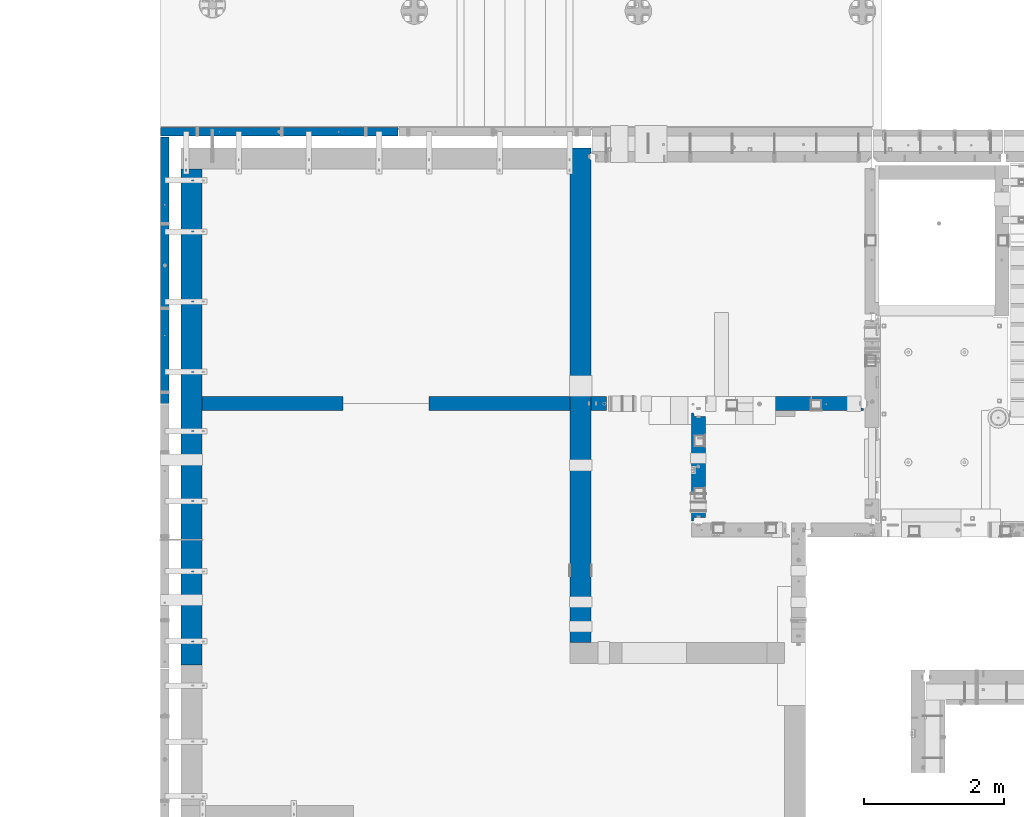
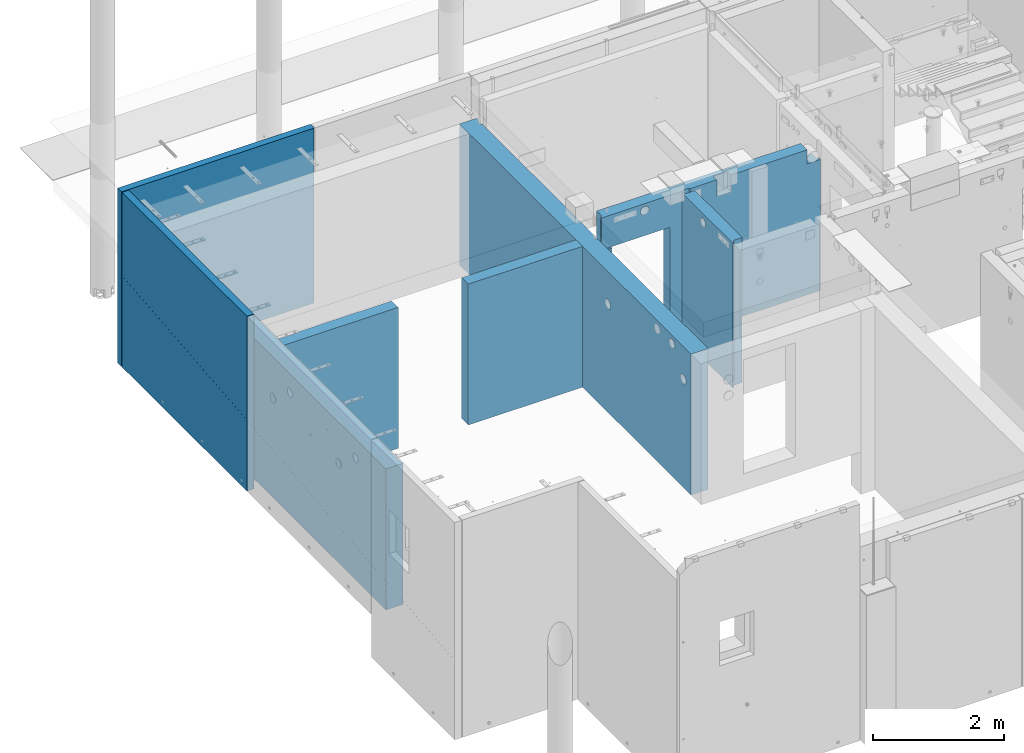
# One storey, part 174 of 264: 9 walls, 8 elements without a shape of their own.
"""IFC2X3 building model written with IfcOpenShell, lengths in millimetres."""

from ifc_helpers import new_model, si_unit, frame, origin_with_axes, place, context, subcontext, project, spatial, faceted_brep, material, type_object, element, aggregate, save


model = new_model("IFC2X3")

# Units and contexts
model_context = context("Model", 3, precision=1e-05, world=origin_with_axes())
body_context = subcontext(model_context, "Body", "Model", "MODEL_VIEW")
ifc_project = project(units=[si_unit("LENGTHUNIT", "METRE", prefix="MILLI"), si_unit("AREAUNIT", "SQUARE_METRE"), si_unit("VOLUMEUNIT", "CUBIC_METRE"), si_unit("MASSUNIT", "GRAM", prefix="KILO"), si_unit("TIMEUNIT", "SECOND"), si_unit("PLANEANGLEUNIT", "RADIAN"), si_unit("SOLIDANGLEUNIT", "STERADIAN"), si_unit("THERMODYNAMICTEMPERATUREUNIT", "DEGREE_CELSIUS"), si_unit("LUMINOUSINTENSITYUNIT", "LUMEN")], contexts=[model_context])

# Site, building, storey
site_placement = place(None, origin_with_axes())
site = spatial("IfcSite", under=ifc_project, at=site_placement, CompositionType="ELEMENT")
building_placement = place(site_placement, origin_with_axes())
building = spatial("IfcBuilding", under=site, at=building_placement, CompositionType="ELEMENT")
storey_placement = place(building_placement, origin_with_axes())
storey = spatial("IfcBuildingStorey", under=building, at=storey_placement, Name="K", CompositionType="ELEMENT", Elevation=0.0)

# Assembly, wall
assembly_1_placement = place(storey_placement, origin_with_axes())
assembly_1 = element("IfcElementAssembly", 1, at=assembly_1_placement, inside=storey, AssemblyPlace="NOTDEFINED", PredefinedType="REINFORCEMENT_UNIT")
ifc_material_1 = material(Name="CONCRETE/Concrete_Undefined")
wall_type_1 = type_object("IfcWallType", PredefinedType="NOTDEFINED")
wall_1_placement = place(assembly_1_placement, frame((13700.0033712105, 16979.999999569, 79645.0), z_axis=(0.0, 0.0, 1.0), x_axis=(1.0, 0.0, 0.0)))
wall_1 = element("IfcWall", 2, at=wall_1_placement, type_object=wall_type_1, material=ifc_material_1, context=body_context, shape_type="Brep", body=[
    faceted_brep([(0.0, 100.0, -1205.0), (0.0, 100.0, 1205.0), (219.998136879898, 100.0, 1205.0), (219.998136879898, 100.0, -1205.0), (0.0, -100.0, 1205.0), (219.998136879898, -100.0, 1205.0), (0.0, -100.0, -1205.0), (219.998136879898, -100.0, -1205.0)], [[[0, 1, 2, 3]], [[1, 4, 5, 2]], [[4, 6, 7, 5]], [[6, 0, 3, 7]], [[5, 7, 3, 2]], [[6, 4, 1, 0]]]),
])

assembly_2_placement = place(storey_placement, origin_with_axes())
assembly_2 = element("IfcElementAssembly", 3, at=assembly_2_placement, inside=storey, AssemblyPlace="NOTDEFINED", PredefinedType="REINFORCEMENT_UNIT")
wall_type_2 = type_object("IfcWallType", PredefinedType="NOTDEFINED")
wall_2_placement = place(assembly_2_placement, frame((11390.0003210833, 16980.0034224637, 79750.0), z_axis=(0.0, 0.0, 1.0), x_axis=(1.0, 0.0, 0.0)))
wall_2 = element("IfcWall", 4, at=wall_2_placement, type_object=wall_type_2, material=ifc_material_1, context=body_context, shape_type="Brep", body=[
    faceted_brep([(0.0, 100.0, -1310.0), (0.0, 100.0, 1310.0), (2010.0, 100.0, 1310.0), (2010.0, 100.0, -1310.0), (0.0, -100.0, 1310.0), (2010.0, -100.0, 1310.0), (0.0, -100.0, -1310.0), (2010.0, -100.0, -1310.0)], [[[0, 1, 2, 3]], [[1, 4, 5, 2]], [[4, 6, 7, 5]], [[6, 0, 3, 7]], [[5, 7, 3, 2]], [[6, 4, 1, 0]]]),
])
aggregate(assembly_2, [wall_2])

assembly_3_placement = place(storey_placement, origin_with_axes())
assembly_3 = element("IfcElementAssembly", 5, at=assembly_3_placement, inside=storey, AssemblyPlace="NOTDEFINED", PredefinedType="REINFORCEMENT_UNIT")
wall_3_placement = place(assembly_3_placement, frame((8150.00032108328, 16980.0034224637, 79750.0), z_axis=(0.0, 0.0, 1.0), x_axis=(1.0, 0.0, 0.0)))
wall_3 = element("IfcWall", 6, at=wall_3_placement, type_object=wall_type_2, material=ifc_material_1, context=body_context, shape_type="Brep", body=[
    faceted_brep([(0.0, 100.0, -1310.0), (0.0, 100.0, 1310.0), (2010.0, 100.0, 1310.0), (2010.0, 100.0, -1310.0), (0.0, -100.0, 1310.0), (2010.0, -100.0, 1310.0), (0.0, -100.0, -1310.0), (2010.0, -100.0, -1310.0)], [[[0, 1, 2, 3]], [[1, 4, 5, 2]], [[4, 6, 7, 5]], [[6, 0, 3, 7]], [[5, 7, 3, 2]], [[6, 4, 1, 0]]]),
])
aggregate(assembly_3, [wall_3])

assembly_4_placement = place(storey_placement, origin_with_axes())
assembly_4 = element("IfcElementAssembly", 7, at=assembly_4_placement, inside=storey, AssemblyPlace="NOTDEFINED", PredefinedType="REINFORCEMENT_UNIT")
ifc_material_2 = material(Name="CONCRETE/C25/30")
wall_type_3 = type_object("IfcWallType", PredefinedType="NOTDEFINED")
wall_4_placement = place(assembly_4_placement, frame((15230.0, 15280.0001284873, 80122.5), z_axis=(0.0, 0.0, 1.0), x_axis=(0.0, 1.0, 0.0)))
wall_4 = element("IfcWall", 8, at=wall_4_placement, type_object=wall_type_3, material=ifc_material_2, context=body_context, shape_type="Brep", body=[
    faceted_brep([(992.588884020672, -100.0, 1168.08857161731), (992.588884020672, 100.0, 1168.08857161731), (985.096352332825, 100.0, 1150.0), (985.096352332825, -100.0, 1150.0), (973.177455637982, 100.0, 1134.46699141101), (973.177455637982, -100.0, 1134.46699141101), (957.644447048991, 100.0, 1122.54809471617), (957.644447048991, -100.0, 1122.54809471617), (939.555875431681, 100.0, 1115.05556302832), (939.555875431681, -100.0, 1115.05556302832), (920.144447048991, 100.0, 1112.5), (920.144447048991, -100.0, 1112.5), (900.733018666302, 100.0, 1115.05556302832), (900.733018666302, -100.0, 1115.05556302832), (882.644447048991, 100.0, 1122.54809471617), (882.644447048991, -100.0, 1122.54809471617), (867.111438460001, 100.0, 1134.46699141101), (867.111438460001, -100.0, 1134.46699141101), (855.192541765158, 100.0, 1150.0), (855.192541765158, -100.0, 1150.0), (847.700010077311, 100.0, 1168.08857161731), (847.700010077311, -100.0, 1168.08857161731), (845.144447048991, 100.0, 1187.5), (845.144447048991, -100.0, 1187.5), (847.700010077311, 100.0, 1206.91142838269), (847.700010077311, -100.0, 1206.91142838269), (855.192541765158, 100.0, 1225.0), (855.192541765158, -100.0, 1225.0), (867.111438460001, 100.0, 1240.53300858899), (867.111438460001, -100.0, 1240.53300858899), (882.644447048991, 100.0, 1252.45190528383), (882.644447048991, -100.0, 1252.45190528383), (900.733018666302, 100.0, 1259.94443697168), (900.733018666302, -100.0, 1259.94443697168), (920.144447048991, 100.0, 1262.5), (920.144447048991, -100.0, 1262.5), (939.555875431681, 100.0, 1259.94443697168), (939.555875431681, -100.0, 1259.94443697168), (957.644447048991, 100.0, 1252.45190528383), (957.644447048991, -100.0, 1252.45190528383), (973.177455637982, 100.0, 1240.53300858899), (973.177455637982, -100.0, 1240.53300858899), (985.096352332825, 100.0, 1225.0), (985.096352332825, -100.0, 1225.0), (992.588884020672, 100.0, 1206.91142838269), (992.588884020672, -100.0, 1206.91142838269), (995.144447048991, 100.0, 1187.5), (995.144447048991, -100.0, 1187.5), (1519.99987151275, -100.0, -1347.5), (1519.99987151275, -100.0, 1347.5), (79.9998715127422, -100.0, 1347.5), (79.9998715127422, -100.0, -1347.5), (1519.99987151275, 57.0, -1347.5), (1519.99987151275, 57.0, 1347.5), (1569.99987151275, 69.9999999999982, 1347.5), (1569.99987151275, 100.0, 1347.5), (29.9998715127422, 100.0, 1347.5), (29.9998715127422, 70.0, 1347.5), (79.9998715127422, 57.0, 1347.5), (29.9998715127422, 100.0, -1347.5), (29.9998715127422, 70.0, -1347.5), (79.9998715127422, 57.0, -1347.5), (1569.99987151275, 100.0, -1347.5), (1569.99987151275, 69.9999999999982, -1347.5)], [[[0, 1, 2, 3]], [[3, 2, 4, 5]], [[5, 4, 6, 7]], [[7, 6, 8, 9]], [[9, 8, 10, 11]], [[11, 10, 12, 13]], [[13, 12, 14, 15]], [[15, 14, 16, 17]], [[17, 16, 18, 19]], [[19, 18, 20, 21]], [[21, 20, 22, 23]], [[23, 22, 24, 25]], [[25, 24, 26, 27]], [[27, 26, 28, 29]], [[29, 28, 30, 31]], [[31, 30, 32, 33]], [[33, 32, 34, 35]], [[35, 34, 36, 37]], [[37, 36, 38, 39]], [[39, 38, 40, 41]], [[41, 40, 42, 43]], [[43, 42, 44, 45]], [[45, 44, 46, 47]], [[47, 46, 1, 0]], [[48, 49, 50, 51], [3, 5, 7, 9, 11, 13, 15, 17, 19, 21, 23, 25, 27, 29, 31, 33, 35, 37, 39, 41, 43, 45, 47, 0]], [[49, 48, 52, 53]], [[49, 53, 54, 55, 56, 57, 58, 50]], [[56, 59, 60, 57]], [[57, 60, 61, 58]], [[50, 58, 61, 51]], [[60, 59, 62, 63, 52, 48, 51, 61]], [[53, 52, 63, 54]], [[62, 55, 54, 63]], [[59, 56, 55, 62], [42, 40, 38, 36, 34, 32, 30, 28, 26, 24, 22, 20, 18, 16, 14, 12, 10, 8, 6, 4, 2, 1, 46, 44]]]),
])
aggregate(assembly_4, [wall_4])

assembly_5_placement = place(storey_placement, origin_with_axes())
assembly_5 = element("IfcElementAssembly", 9, at=assembly_5_placement, inside=storey, AssemblyPlace="NOTDEFINED", PredefinedType="REINFORCEMENT_UNIT")
ifc_material_3 = material(Name="CONCRETE/C30/37")
wall_5_placement = place(assembly_5_placement, frame((13729.9991042544, 16980.0, 80122.5), z_axis=(0.0, 0.0, 1.0), x_axis=(1.0, 0.0, 0.0)))
wall_5 = element("IfcWall", 10, at=wall_5_placement, type_object=wall_type_3, material=ifc_material_3, context=body_context, shape_type="Brep", body=[
    faceted_brep([(3620.00051278574, 100.000000075132, 1347.5), (3620.00051278574, -100.0, 1347.5), (3620.00051278574, -100.0, 1087.5), (3620.00051278574, 100.000000371449, 1087.5), (3854.99999398691, -72.1666613361449, 1087.5), (3820.00089558421, -57.0000048420043, 1087.5), (3820.00089558421, 100.00000001011, 1087.5), (3855.0, -100.0, 1087.5), (2280.00093240244, -100.0, 1037.5), (2280.00093240244, 9.99999999999636, 1037.5), (2030.00093240244, 9.99999999999636, 1037.5), (2030.00093240244, -100.0, 1037.5), (2280.00093240244, 9.99999999999636, 1347.5), (2280.00093240244, -100.0, 1347.5), (2030.00093240244, 9.99999999999636, 1347.5), (2030.00093240244, -100.0, 1347.5), (1565.00089574558, -100.0, 1347.5), (1552.00089574558, -80.0, 1347.5), (1552.00089574558, -80.0, -1347.5), (1565.00089574558, -100.0, -1347.5), (1448.00089574558, -80.0, 1347.5), (1448.00089574558, -80.0, -1347.5), (1435.00089574558, -100.0, 1347.5), (1435.00089574558, -100.0, -1347.5), (3855.0, -100.0, -1347.5), (1209.99657178411, -100.0, -1347.5), (1209.99657178411, 100.0, -1347.5), (3820.00089558421, 100.0, -1347.5), (3820.00089558421, -57.0000048420043, -1347.5), (3855.0, -72.1666613361449, -1347.5), (30.0, 100.0, 1347.5), (30.0000423138954, -56.9999995350736, 1347.5), (0.0, -70.0, 1347.5), (0.0, -100.0, 1347.5), (0.0, -100.0, 752.5), (0.0, -70.0, 752.5), (30.0000423138954, -56.9999995350736, 752.5), (30.0000386454594, 100.0, 752.5), (1209.99657178411, 100.0, 752.5), (1209.99657178411, -100.0, 752.5), (825.234667520259, -100.0, 1185.0), (813.315770825417, -100.0, 1169.46699141101), (797.782762236426, -100.0, 1157.54809471617), (779.694190619115, -100.0, 1150.05556302832), (760.282762236426, -100.0, 1147.5), (740.871333853736, -100.0, 1150.05556302832), (722.782762236426, -100.0, 1157.54809471617), (707.249753647435, -100.0, 1169.46699141101), (695.330856952593, -100.0, 1185.0), (687.838325264745, -100.0, 1203.08857161731), (685.282762236426, -100.0, 1222.5), (687.838325264745, -100.0, 1241.91142838269), (695.330856952593, -100.0, 1260.0), (707.249753647435, -100.0, 1275.53300858899), (722.782762236426, -100.0, 1287.45190528383), (740.871333853736, -100.0, 1294.94443697168), (760.282762236426, -100.0, 1297.5), (779.694190619115, -100.0, 1294.94443697168), (797.782762236426, -100.0, 1287.45190528383), (813.315770825417, -100.0, 1275.53300858899), (825.234667520259, -100.0, 1260.0), (832.727199208106, -100.0, 1241.91142838269), (835.282762236426, -100.0, 1222.5), (832.727199208106, -100.0, 1203.08857161731), (832.727199208106, 100.0, 1203.08857161731), (835.282762236426, 100.0, 1222.5), (825.234667520259, 100.0, 1185.0), (813.315770825417, 100.0, 1169.46699141101), (797.782762236426, 100.0, 1157.54809471617), (779.694190619115, 100.0, 1150.05556302832), (760.282762236426, 100.0, 1147.5), (740.871333853736, 100.0, 1150.05556302832), (722.782762236426, 100.0, 1157.54809471617), (707.249753647435, 100.0, 1169.46699141101), (695.330856952593, 100.0, 1185.0), (687.838325264745, 100.0, 1203.08857161731), (685.282762236426, 100.0, 1222.5), (687.838325264745, 100.0, 1241.91142838269), (695.330856952593, 100.0, 1260.0), (707.249753647435, 100.0, 1275.53300858899), (722.782762236426, 100.0, 1287.45190528383), (740.871333853736, 100.0, 1294.94443697168), (760.282762236426, 100.0, 1297.5), (779.694190619115, 100.0, 1294.94443697168), (797.782762236426, 100.0, 1287.45190528383), (813.315770825417, 100.0, 1275.53300858899), (825.234667520259, 100.0, 1260.0), (832.727199208106, 100.0, 1241.91142838269)], [[[0, 1, 2, 3]], [[4, 5, 6, 3, 2, 7]], [[8, 9, 10, 11]], [[12, 9, 8, 13]], [[14, 10, 9, 12]], [[15, 11, 10, 14]], [[16, 17, 18, 19]], [[20, 21, 18, 17]], [[22, 23, 21, 20]], [[24, 19, 18, 21, 23, 25, 26, 27, 28, 29]], [[24, 29, 4, 7]], [[1, 13, 8, 11, 15, 16, 19, 24, 7, 2]], [[30, 31, 32, 33, 22, 20, 17, 16, 15, 14, 12, 13, 1, 0]], [[34, 33, 32, 35]], [[31, 36, 35, 32]], [[30, 37, 36, 31]], [[38, 39, 34, 35, 36, 37]], [[26, 25, 39, 38]], [[23, 22, 33, 34, 39, 25], [40, 41, 42, 43, 44, 45, 46, 47, 48, 49, 50, 51, 52, 53, 54, 55, 56, 57, 58, 59, 60, 61, 62, 63]], [[64, 63, 62, 65]], [[66, 40, 63, 64]], [[67, 41, 40, 66]], [[68, 42, 41, 67]], [[69, 43, 42, 68]], [[70, 44, 43, 69]], [[71, 45, 44, 70]], [[72, 46, 45, 71]], [[73, 47, 46, 72]], [[74, 48, 47, 73]], [[75, 49, 48, 74]], [[76, 50, 49, 75]], [[77, 51, 50, 76]], [[78, 52, 51, 77]], [[79, 53, 52, 78]], [[80, 54, 53, 79]], [[81, 55, 54, 80]], [[82, 56, 55, 81]], [[83, 57, 56, 82]], [[84, 58, 57, 83]], [[85, 59, 58, 84]], [[86, 60, 59, 85]], [[87, 61, 60, 86]], [[65, 62, 61, 87]], [[27, 26, 38, 37, 30, 0, 3, 6], [86, 85, 84, 83, 82, 81, 80, 79, 78, 77, 76, 75, 74, 73, 72, 71, 70, 69, 68, 67, 66, 64, 65, 87]], [[28, 27, 6, 5]], [[29, 28, 5, 4]]]),
])
aggregate(assembly_5, [wall_5])

assembly_6_placement = place(storey_placement, origin_with_axes())
assembly_6 = element("IfcElementAssembly", 11, at=assembly_6_placement, inside=storey, AssemblyPlace="NOTDEFINED", PredefinedType="REINFORCEMENT_UNIT")
ifc_material_4 = material(Name="CONCRETE/C40/50")
wall_type_4 = type_object("IfcWallType", PredefinedType="NOTDEFINED")
wall_6_placement = place(assembly_6_placement, frame((7620.0, 16985.0, 80115.0), z_axis=(0.0, 0.0, 1.0), x_axis=(0.0, 1.0, 0.0)))
wall_6 = element("IfcWall", 12, at=wall_6_placement, type_object=wall_type_4, material=ifc_material_4, context=body_context, shape_type="Brep", body=[
    faceted_brep([(3800.0, 60.0, 71.9251981614216), (0.0, 60.0, -308.074801838578), (0.0, 59.0002685189247, -308.074801838578), (3800.0, 59.0002685189247, 71.9251981614216), (3800.0, 59.0002685189247, 87.000011593118), (0.0, 59.0002685189247, -292.999988406882), (0.0, 60.0, -292.999988406897), (3800.0, 60.0, 87.0000115931034), (3.63797880709171e-12, -59.9999999999927, -1625.0), (1.81898940354586e-12, 60.0000000000036, -1625.0), (3800.0, 60.0, -1625.0), (3800.0, -60.0, -1625.0), (3.63797880709171e-12, -59.9999999999927, 1625.0), (3800.0, -60.0, 1625.0), (1.81898940354586e-12, 60.0000000000036, 1625.0), (3800.0, 60.0, 1625.0)], [[[0, 1, 2, 3]], [[4, 5, 6, 7]], [[3, 2, 5, 4]], [[8, 9, 10, 11]], [[12, 8, 11, 13]], [[14, 12, 13, 15]], [[14, 15, 7, 6]], [[1, 9, 8, 12, 14, 6, 5, 2]], [[10, 9, 1, 0]], [[15, 13, 11, 10, 0, 3, 4, 7]]]),
])
aggregate(assembly_6, [wall_6])

assembly_7_placement = place(storey_placement, origin_with_axes())
assembly_7 = element("IfcElementAssembly", 13, at=assembly_7_placement, inside=storey, AssemblyPlace="NOTDEFINED", PredefinedType="REINFORCEMENT_UNIT")
wall_7_placement = place(assembly_7_placement, frame((7560.0, 20860.0, 80115.0), z_axis=(0.0, 0.0, 1.0), x_axis=(1.0, 0.0, 0.0)))
wall_7 = element("IfcWall", 14, at=wall_7_placement, type_object=wall_type_4, material=ifc_material_4, context=body_context, shape_type="Brep", body=[
    faceted_brep([(3385.0, 40.0, 385.0), (1515.0, 40.0, 385.0), (1515.0, 40.0, 485.0), (3385.0, 40.0, 485.0), (3385.0, 60.0, 385.0), (1515.0, 60.0, 385.0), (1515.0, 60.0, 485.0), (3385.0, 60.0, 485.0), (3.63797880709171e-12, -59.9999999999927, -1625.0), (3.63797880709171e-12, -59.9999999999927, 1625.0), (1.81898940354586e-12, 60.0000000000036, 1625.0), (1.81898940354586e-12, 60.0000000000036, -1625.0), (3385.0, 60.0, -1625.0), (3385.0, -60.0, -1625.0), (3385.0, -60.0, 1625.0), (3385.0, 60.0, 1625.0)], [[[0, 1, 2, 3]], [[4, 5, 1, 0]], [[6, 2, 1, 5]], [[7, 3, 2, 6]], [[8, 9, 10, 11]], [[8, 11, 12, 13]], [[9, 8, 13, 14]], [[10, 9, 14, 15]], [[5, 4, 12, 11, 10, 15, 7, 6]], [[15, 14, 13, 12, 4, 0, 3, 7]]]),
])
aggregate(assembly_7, [wall_7])

# Wall
wall_type_5 = type_object("IfcWallType", PredefinedType="NOTDEFINED")
wall_8_placement = place(assembly_1_placement, frame((13550.0033728411, 13575.0031172879, 79750.0), z_axis=(0.0, 0.0, 1.0), x_axis=(0.0, 1.0, 0.0)))
wall_8 = element("IfcWall", 15, at=wall_8_placement, type_object=wall_type_5, material=ifc_material_1, context=body_context, shape_type="Brep", body=[
    faceted_brep([(3367.99688226059, -129.99999734863, 1310.0), (3367.99688226059, -129.99999734863, 1100.0), (3441.99688230155, -129.99999939036, 1100.0), (3441.99688230155, -129.99999939036, 1310.0), (3354.99688298958, -150.0, 1310.0), (3354.99688298958, -149.999998131263, 1100.0), (3454.99688271211, -150.0, 1100.0), (3454.99688271211, -150.0, 1310.0), (6892.99688271211, -130.0, -1300.0), (6892.99688226059, -129.999997348625, -1310.0), (6966.99688230153, -129.999999390373, -1310.0), (6966.99688271211, -130.0, -1300.0), (6879.99688271211, -150.0, -1300.0), (6879.99688298958, -150.0, -1310.0), (0.0, -150.0, -1310.0), (0.0, -150.0, 1310.0), (0.0, 150.0, 1310.0), (0.0, 150.0, -1310.0), (297.868543651701, -149.999999999996, 750.0), (297.868543651701, 150.0, 750.0), (305.860577452071, 150.0, 730.705523608209), (305.860577452071, -149.999999999996, 730.705523608209), (285.15505384387, -149.999999999996, 766.568542494919), (285.15505384387, 150.0, 766.568542494919), (268.586511348945, -149.999999999996, 779.282032302755), (268.586511348945, 150.0, 779.282032302755), (249.292034957147, -149.999999999996, 787.274066103128), (249.292034957147, 150.0, 787.274066103128), (228.586511348945, -149.999999999996, 790.0), (228.586511348945, 150.0, 790.0), (207.880987740744, -149.999999999996, 787.274066103128), (207.880987740744, 150.0, 787.274066103128), (188.586511348945, -149.999999999996, 779.282032302755), (188.586511348945, 150.0, 779.282032302755), (172.017968854021, -149.999999999996, 766.568542494919), (172.017968854021, 150.0, 766.568542494919), (159.30447904619, -149.999999999996, 750.0), (159.30447904619, 150.0, 750.0), (151.31244524582, -149.999999999996, 730.705523608209), (151.31244524582, 150.0, 730.705523608209), (148.586511348945, -149.999999999996, 710.0), (148.586511348945, 150.0, 710.0), (151.31244524582, -149.999999999996, 689.294476391791), (151.31244524582, 150.0, 689.294476391791), (159.30447904619, -149.999999999996, 670.0), (159.30447904619, 150.0, 670.0), (172.017968854021, -149.999999999996, 653.431457505081), (172.017968854021, 150.0, 653.431457505081), (188.586511348945, -149.999999999996, 640.717967697245), (188.586511348945, 150.0, 640.717967697245), (207.880987740744, -149.999999999996, 632.725933896872), (207.880987740744, 150.0, 632.725933896872), (228.586511348945, -149.999999999996, 630.0), (228.586511348945, 150.0, 630.0), (249.292034957147, -149.999999999996, 632.725933896872), (249.292034957147, 150.0, 632.725933896872), (268.586511348945, -149.999999999996, 640.717967697245), (268.586511348945, 150.0, 640.717967697245), (285.15505384387, -149.999999999996, 653.431457505081), (285.15505384387, 150.0, 653.431457505081), (297.868543651701, -149.999999999996, 670.0), (297.868543651701, 150.0, 670.0), (305.860577452071, -149.999999999996, 689.294476391791), (305.860577452071, 150.0, 689.294476391791), (308.586511348945, -149.999999999996, 710.0), (308.586511348945, 150.0, 710.0), (644.474798229337, -149.999999999996, 1200.0), (644.474798229337, 150.0, 1200.0), (652.466832029708, 150.0, 1180.70552360821), (652.466832029708, -149.999999999996, 1180.70552360821), (631.761308421506, -149.999999999996, 1216.56854249492), (631.761308421506, 150.0, 1216.56854249492), (615.192765926582, -149.999999999996, 1229.28203230276), (615.192765926582, 150.0, 1229.28203230276), (595.898289534784, -149.999999999996, 1237.27406610313), (595.898289534784, 150.0, 1237.27406610313), (575.192765926582, -149.999999999996, 1240.0), (575.192765926582, 150.0, 1240.0), (554.487242318381, -149.999999999996, 1237.27406610313), (554.487242318381, 150.0, 1237.27406610313), (535.192765926582, -149.999999999996, 1229.28203230276), (535.192765926582, 150.0, 1229.28203230276), (518.624223431658, -149.999999999996, 1216.56854249492), (518.624223431658, 150.0, 1216.56854249492), (505.910733623827, -149.999999999996, 1200.0), (505.910733623827, 150.0, 1200.0), (497.918699823456, -149.999999999996, 1180.70552360821), (497.918699823456, 150.0, 1180.70552360821), (495.192765926582, -149.999999999996, 1160.0), (495.192765926582, 150.0, 1160.0), (497.918699823456, -149.999999999996, 1139.29447639179), (497.918699823456, 150.0, 1139.29447639179), (505.910733623827, -149.999999999996, 1120.0), (505.910733623827, 150.0, 1120.0), (518.624223431658, -149.999999999996, 1103.43145750508), (518.624223431658, 150.0, 1103.43145750508), (535.192765926582, -149.999999999996, 1090.71796769724), (535.192765926582, 150.0, 1090.71796769724), (554.487242318381, -149.999999999996, 1082.72593389687), (554.487242318381, 150.0, 1082.72593389687), (575.192765926582, -149.999999999996, 1080.0), (575.192765926582, 150.0, 1080.0), (595.898289534784, -149.999999999996, 1082.72593389687), (595.898289534784, 150.0, 1082.72593389687), (615.192765926582, -149.999999999996, 1090.71796769724), (615.192765926582, 150.0, 1090.71796769724), (631.761308421506, -149.999999999996, 1103.43145750508), (631.761308421506, 150.0, 1103.43145750508), (644.474798229337, -149.999999999996, 1120.0), (644.474798229337, 150.0, 1120.0), (652.466832029708, -149.999999999996, 1139.29447639179), (652.466832029708, 150.0, 1139.29447639179), (655.192765926582, -149.999999999996, 1160.0), (655.192765926582, 150.0, 1160.0), (2597.97459223568, -149.999999999998, 750.0), (2597.97459223568, 150.0, 750.0), (2605.96662603605, 150.0, 730.705523608209), (2605.96662603605, -149.999999999998, 730.705523608209), (2585.26110242785, -149.999999999998, 766.568542494919), (2585.26110242785, 150.0, 766.568542494919), (2568.69255993293, -149.999999999998, 779.282032302755), (2568.69255993293, 150.0, 779.282032302755), (2549.39808354113, -149.999999999998, 787.274066103128), (2549.39808354113, 150.0, 787.274066103128), (2528.69255993293, -149.999999999998, 790.0), (2528.69255993293, 150.0, 790.0), (2507.98703632473, -149.999999999998, 787.274066103128), (2507.98703632473, 150.0, 787.274066103128), (2488.69255993293, -149.999999999998, 779.282032302755), (2488.69255993293, 150.0, 779.282032302755), (2472.124017438, -149.999999999998, 766.568542494919), (2472.124017438, 150.0, 766.568542494919), (2459.41052763017, -149.999999999998, 750.0), (2459.41052763017, 150.0, 750.0), (2451.4184938298, -149.999999999998, 730.705523608209), (2451.4184938298, 150.0, 730.705523608209), (2448.69255993293, -149.999999999998, 710.0), (2448.69255993293, 150.0, 710.0), (2451.4184938298, -149.999999999998, 689.294476391791), (2451.4184938298, 150.0, 689.294476391791), (2459.41052763017, -149.999999999998, 670.0), (2459.41052763017, 150.0, 670.0), (2472.124017438, -149.999999999998, 653.431457505081), (2472.124017438, 150.0, 653.431457505081), (2488.69255993293, -149.999999999998, 640.717967697245), (2488.69255993293, 150.0, 640.717967697245), (2507.98703632473, -149.999999999998, 632.725933896872), (2507.98703632473, 150.0, 632.725933896872), (2528.69255993293, -149.999999999998, 630.0), (2528.69255993293, 150.0, 630.0), (2549.39808354113, -149.999999999998, 632.725933896872), (2549.39808354113, 150.0, 632.725933896872), (2568.69255993293, -149.999999999998, 640.717967697245), (2568.69255993293, 150.0, 640.717967697245), (2585.26110242785, -149.999999999998, 653.431457505081), (2585.26110242785, 150.0, 653.431457505081), (2597.97459223568, -149.999999999998, 670.0), (2597.97459223568, 150.0, 670.0), (2605.96662603605, -149.999999999998, 689.294476391791), (2605.96662603605, 150.0, 689.294476391791), (2608.69255993293, -149.999999999998, 710.0), (2608.69255993293, 150.0, 710.0), (7055.00030517578, 150.0, 1310.0), (7055.00030517578, 150.0, -1310.0), (7055.00030517578, -150.0, 1310.0), (7055.00030517578, -150.0, -1310.0), (6979.99688271211, -150.0, 1310.0), (6979.99688271211, -150.0, -1300.0), (6979.99688271211, -150.0, -1310.0), (6966.99688271211, -130.0, 1310.0), (6892.99688271211, -130.0, 1310.0), (6879.99688271211, -150.0, 1310.0)], [[[0, 1, 2, 3]], [[4, 5, 1, 0]], [[6, 2, 1, 5]], [[7, 3, 2, 6]], [[8, 9, 10, 11]], [[12, 13, 9, 8]], [[14, 15, 16, 17]], [[18, 19, 20, 21]], [[22, 23, 19, 18]], [[24, 25, 23, 22]], [[26, 27, 25, 24]], [[28, 29, 27, 26]], [[30, 31, 29, 28]], [[32, 33, 31, 30]], [[34, 35, 33, 32]], [[36, 37, 35, 34]], [[38, 39, 37, 36]], [[40, 41, 39, 38]], [[42, 43, 41, 40]], [[44, 45, 43, 42]], [[46, 47, 45, 44]], [[48, 49, 47, 46]], [[50, 51, 49, 48]], [[52, 53, 51, 50]], [[54, 55, 53, 52]], [[56, 57, 55, 54]], [[58, 59, 57, 56]], [[60, 61, 59, 58]], [[62, 63, 61, 60]], [[64, 65, 63, 62]], [[21, 20, 65, 64]], [[66, 67, 68, 69]], [[70, 71, 67, 66]], [[72, 73, 71, 70]], [[74, 75, 73, 72]], [[76, 77, 75, 74]], [[78, 79, 77, 76]], [[80, 81, 79, 78]], [[82, 83, 81, 80]], [[84, 85, 83, 82]], [[86, 87, 85, 84]], [[88, 89, 87, 86]], [[90, 91, 89, 88]], [[92, 93, 91, 90]], [[94, 95, 93, 92]], [[96, 97, 95, 94]], [[98, 99, 97, 96]], [[100, 101, 99, 98]], [[102, 103, 101, 100]], [[104, 105, 103, 102]], [[106, 107, 105, 104]], [[108, 109, 107, 106]], [[110, 111, 109, 108]], [[112, 113, 111, 110]], [[69, 68, 113, 112]], [[114, 115, 116, 117]], [[118, 119, 115, 114]], [[120, 121, 119, 118]], [[122, 123, 121, 120]], [[124, 125, 123, 122]], [[126, 127, 125, 124]], [[128, 129, 127, 126]], [[130, 131, 129, 128]], [[132, 133, 131, 130]], [[134, 135, 133, 132]], [[136, 137, 135, 134]], [[138, 139, 137, 136]], [[140, 141, 139, 138]], [[142, 143, 141, 140]], [[144, 145, 143, 142]], [[146, 147, 145, 144]], [[148, 149, 147, 146]], [[150, 151, 149, 148]], [[152, 153, 151, 150]], [[154, 155, 153, 152]], [[156, 157, 155, 154]], [[158, 159, 157, 156]], [[160, 161, 159, 158]], [[117, 116, 161, 160]], [[17, 16, 162, 163], [115, 119, 121, 123, 125, 127, 129, 131, 133, 135, 137, 139, 141, 143, 145, 147, 149, 151, 153, 155, 157, 159, 161, 116], [67, 71, 73, 75, 77, 79, 81, 83, 85, 87, 89, 91, 93, 95, 97, 99, 101, 103, 105, 107, 109, 111, 113, 68], [19, 23, 25, 27, 29, 31, 33, 35, 37, 39, 41, 43, 45, 47, 49, 51, 53, 55, 57, 59, 61, 63, 65, 20]], [[164, 165, 163, 162]], [[165, 164, 166, 167, 168]], [[9, 13, 14, 17, 163, 165, 168, 10]], [[167, 11, 10, 168]], [[166, 169, 11, 167]], [[170, 8, 11, 169]], [[171, 12, 8, 170]], [[5, 4, 15, 14, 13, 12, 171, 7, 6], [156, 154, 152, 150, 148, 146, 144, 142, 140, 138, 136, 134, 132, 130, 128, 126, 124, 122, 120, 118, 114, 117, 160, 158], [108, 106, 104, 102, 100, 98, 96, 94, 92, 90, 88, 86, 84, 82, 80, 78, 76, 74, 72, 70, 66, 69, 112, 110], [60, 58, 56, 54, 52, 50, 48, 46, 44, 42, 40, 38, 36, 34, 32, 30, 28, 26, 24, 22, 18, 21, 64, 62]], [[171, 170, 169, 166, 164, 162, 16, 15, 4, 0, 3, 7]]]),
])

aggregate(assembly_1, [wall_1, wall_8])

# Assembly, wall
assembly_8_placement = place(storey_placement, origin_with_axes())
assembly_8 = element("IfcElementAssembly", 16, at=assembly_8_placement, inside=storey, AssemblyPlace="NOTDEFINED", PredefinedType="REINFORCEMENT_UNIT")
wall_9_placement = place(assembly_8_placement, frame((8000.00032108328, 13255.0, 79750.0), z_axis=(0.0, 0.0, 1.0), x_axis=(0.0, 1.0, 0.0)))
wall_9 = element("IfcWall", 17, at=wall_9_placement, type_object=wall_type_5, material=ifc_material_1, context=body_context, shape_type="Brep", body=[
    faceted_brep([(3002.27322537961, -150.0, 939.294476391791), (3002.27322537961, 150.0, 939.294476391791), (2994.28119157924, 150.0, 920.0), (2994.28119157924, -150.0, 920.0), (2981.56770177141, 150.0, 903.431457505081), (2981.56770177141, -150.0, 903.431457505081), (2964.99915927648, 150.0, 890.717967697245), (2964.99915927648, -150.0, 890.717967697245), (2945.70468288469, 150.0, 882.725933896872), (2945.70468288469, -150.0, 882.725933896872), (2924.99915927648, 150.0, 880.0), (2924.99915927648, -150.0, 880.0), (2904.29363566828, 150.0, 882.725933896872), (2904.29363566828, -150.0, 882.725933896872), (2884.99915927648, 150.0, 890.717967697245), (2884.99915927648, -150.0, 890.717967697245), (2868.43061678156, 150.0, 903.431457505081), (2868.43061678156, -150.0, 903.431457505081), (2855.71712697373, 150.0, 920.0), (2855.71712697373, -150.0, 920.0), (2847.72509317336, 150.0, 939.294476391791), (2847.72509317336, -150.0, 939.294476391791), (2844.99915927648, 150.0, 960.0), (2844.99915927648, -150.0, 960.0), (2847.72509317336, 150.0, 980.705523608209), (2847.72509317336, -150.0, 980.705523608209), (2855.71712697373, 150.0, 1000.0), (2855.71712697373, -150.0, 1000.0), (2868.43061678156, 150.0, 1016.56854249492), (2868.43061678156, -150.0, 1016.56854249492), (2884.99915927648, 150.0, 1029.28203230276), (2884.99915927648, -150.0, 1029.28203230276), (2904.29363566828, 150.0, 1037.27406610313), (2904.29363566828, -150.0, 1037.27406610313), (2924.99915927648, 150.0, 1040.0), (2924.99915927648, -150.0, 1040.0), (2945.70468288469, 150.0, 1037.27406610313), (2945.70468288469, -150.0, 1037.27406610313), (2964.99915927648, 150.0, 1029.28203230276), (2964.99915927648, -150.0, 1029.28203230276), (2981.56770177141, 150.0, 1016.56854249492), (2981.56770177141, -150.0, 1016.56854249492), (2994.28119157924, 150.0, 1000.0), (2994.28119157924, -150.0, 1000.0), (3002.27322537961, 150.0, 980.705523608209), (3002.27322537961, -150.0, 980.705523608209), (3004.99915927648, 150.0, 960.0), (3004.99915927648, -150.0, 960.0), (0.0, 150.0, 1310.0), (0.0, -150.0, 1310.0), (7075.00037070586, -150.0, 1310.0), (7075.00037070586, 150.0, 1310.0), (0.0, -150.0, -1310.0), (0.0, 150.0, -1310.0), (7075.00037070586, 150.0, -1310.0), (7075.00037070586, -150.0, -1310.0), (1002.27417905393, -150.0, 980.705523608209), (1002.27417905393, 150.0, 980.705523608209), (1005.0001129508, 150.0, 960.0), (1005.0001129508, -150.0, 960.0), (994.282145253557, -150.0, 1000.0), (994.282145253557, 150.0, 1000.0), (981.568655445726, -150.0, 1016.56854249492), (981.568655445726, 150.0, 1016.56854249492), (965.000112950802, -150.0, 1029.28203230276), (965.000112950802, 150.0, 1029.28203230276), (945.705636559003, -150.0, 1037.27406610313), (945.705636559003, 150.0, 1037.27406610313), (925.000112950802, -150.0, 1040.0), (925.000112950802, 150.0, 1040.0), (904.2945893426, -150.0, 1037.27406610313), (904.2945893426, 150.0, 1037.27406610313), (885.000112950802, -150.0, 1029.28203230276), (885.000112950802, 150.0, 1029.28203230276), (868.431570455878, -150.0, 1016.56854249492), (868.431570455878, 150.0, 1016.56854249492), (855.718080648046, -150.0, 1000.0), (855.718080648046, 150.0, 1000.0), (847.726046847676, -150.0, 980.705523608209), (847.726046847676, 150.0, 980.705523608209), (845.000112950802, -150.0, 960.0), (845.000112950802, 150.0, 960.0), (847.726046847676, -150.0, 939.294476391791), (847.726046847676, 150.0, 939.294476391791), (855.718080648046, -150.0, 920.0), (855.718080648046, 150.0, 920.0), (868.431570455878, -150.0, 903.431457505081), (868.431570455878, 150.0, 903.431457505081), (885.000112950802, -150.0, 890.717967697245), (885.000112950802, 150.0, 890.717967697245), (904.2945893426, -150.0, 882.725933896872), (904.2945893426, 150.0, 882.725933896872), (925.000112950802, -150.0, 880.0), (925.000112950802, 150.0, 880.0), (945.705636559003, -150.0, 882.725933896872), (945.705636559003, 150.0, 882.725933896872), (965.000112950802, -150.0, 890.717967697245), (965.000112950802, 150.0, 890.717967697245), (981.568655445726, -150.0, 903.431457505081), (981.568655445726, 150.0, 903.431457505081), (994.282145253557, -150.0, 920.0), (994.282145253557, 150.0, 920.0), (1002.27417905393, -150.0, 939.294476391791), (1002.27417905393, 150.0, 939.294476391791), (1785.0001129508, -150.0, 950.0), (1777.92904513894, -150.0, 952.928932188137), (1775.0001129508, -150.0, 960.0), (1777.92904513894, -150.0, 967.071067811863), (1785.0001129508, -150.0, 970.0), (1792.07118076267, -150.0, 967.071067811863), (1795.0001129508, -150.0, 960.0), (1792.07118076267, -150.0, 952.928932188137), (1785.0001129508, 150.0, 970.0), (1792.07118076267, 150.0, 967.071067811863), (1777.92904513894, 150.0, 967.071067811863), (1775.0001129508, 150.0, 960.0), (1777.92904513894, 150.0, 952.928932188137), (1785.0001129508, 150.0, 950.0), (1792.07118076267, 150.0, 952.928932188137), (1795.0001129508, 150.0, 960.0)], [[[0, 1, 2, 3]], [[3, 2, 4, 5]], [[5, 4, 6, 7]], [[7, 6, 8, 9]], [[9, 8, 10, 11]], [[11, 10, 12, 13]], [[13, 12, 14, 15]], [[15, 14, 16, 17]], [[17, 16, 18, 19]], [[19, 18, 20, 21]], [[21, 20, 22, 23]], [[23, 22, 24, 25]], [[25, 24, 26, 27]], [[27, 26, 28, 29]], [[29, 28, 30, 31]], [[31, 30, 32, 33]], [[33, 32, 34, 35]], [[35, 34, 36, 37]], [[37, 36, 38, 39]], [[39, 38, 40, 41]], [[41, 40, 42, 43]], [[43, 42, 44, 45]], [[45, 44, 46, 47]], [[47, 46, 1, 0]], [[48, 49, 50, 51]], [[52, 49, 48, 53]], [[52, 53, 54, 55]], [[50, 55, 54, 51]], [[56, 57, 58, 59]], [[60, 61, 57, 56]], [[62, 63, 61, 60]], [[64, 65, 63, 62]], [[66, 67, 65, 64]], [[68, 69, 67, 66]], [[70, 71, 69, 68]], [[72, 73, 71, 70]], [[74, 75, 73, 72]], [[76, 77, 75, 74]], [[78, 79, 77, 76]], [[80, 81, 79, 78]], [[82, 83, 81, 80]], [[84, 85, 83, 82]], [[86, 87, 85, 84]], [[88, 89, 87, 86]], [[90, 91, 89, 88]], [[92, 93, 91, 90]], [[94, 95, 93, 92]], [[96, 97, 95, 94]], [[98, 99, 97, 96]], [[100, 101, 99, 98]], [[102, 103, 101, 100]], [[59, 58, 103, 102]], [[49, 52, 55, 50], [3, 5, 7, 9, 11, 13, 15, 17, 19, 21, 23, 25, 27, 29, 31, 33, 35, 37, 39, 41, 43, 45, 47, 0], [104, 105, 106, 107, 108, 109, 110, 111], [100, 98, 96, 94, 92, 90, 88, 86, 84, 82, 80, 78, 76, 74, 72, 70, 68, 66, 64, 62, 60, 56, 59, 102]], [[108, 112, 113, 109]], [[107, 114, 112, 108]], [[106, 115, 114, 107]], [[105, 116, 115, 106]], [[104, 117, 116, 105]], [[111, 118, 117, 104]], [[110, 119, 118, 111]], [[109, 113, 119, 110]], [[53, 48, 51, 54], [42, 40, 38, 36, 34, 32, 30, 28, 26, 24, 22, 20, 18, 16, 14, 12, 10, 8, 6, 4, 2, 1, 46, 44], [112, 114, 115, 116, 117, 118, 119, 113], [61, 63, 65, 67, 69, 71, 73, 75, 77, 79, 81, 83, 85, 87, 89, 91, 93, 95, 97, 99, 101, 103, 58, 57]]]),
])
aggregate(assembly_8, [wall_9])

save(model, "model.ifc")
